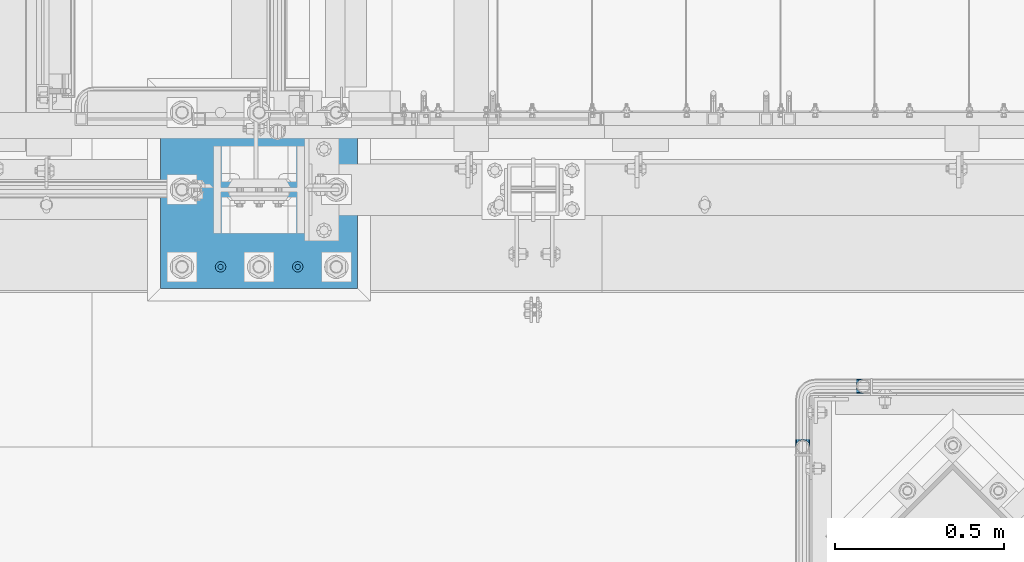
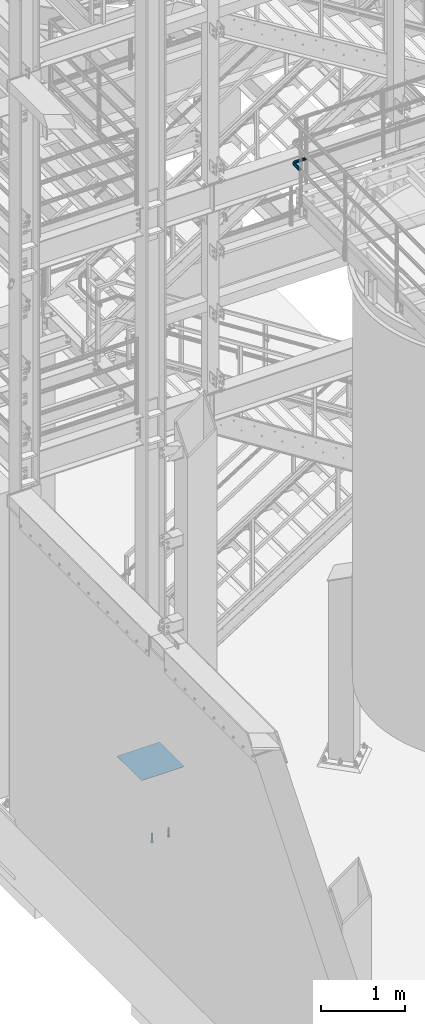
# One storey, part 1129 of 1876: 4 beams, 2 elements without a shape of their own.
"""IFC2X3 building model written with IfcOpenShell, lengths in millimetres."""

from ifc_helpers import new_model, si_unit, frame, origin_with_axes, place, context, subcontext, project, spatial, faceted_brep, material, type_object, element, aggregate, save


model = new_model("IFC2X3")

# Units and contexts
model_context = context("Model", 3, precision=1e-05, world=origin_with_axes())
body_context = subcontext(model_context, "Body", "Model", "MODEL_VIEW")
ifc_project = project(units=[si_unit("LENGTHUNIT", "METRE", prefix="MILLI"), si_unit("AREAUNIT", "SQUARE_METRE"), si_unit("VOLUMEUNIT", "CUBIC_METRE"), si_unit("MASSUNIT", "GRAM", prefix="KILO"), si_unit("TIMEUNIT", "SECOND"), si_unit("PLANEANGLEUNIT", "RADIAN"), si_unit("SOLIDANGLEUNIT", "STERADIAN"), si_unit("THERMODYNAMICTEMPERATUREUNIT", "DEGREE_CELSIUS"), si_unit("LUMINOUSINTENSITYUNIT", "LUMEN")], contexts=[model_context])

# Site, building, storey
site_placement = place(None, origin_with_axes())
site = spatial("IfcSite", under=ifc_project, at=site_placement, CompositionType="ELEMENT")
building_placement = place(site_placement, origin_with_axes())
building = spatial("IfcBuilding", under=site, at=building_placement, Name="Undefined", CompositionType="ELEMENT")
storey_placement = place(building_placement, origin_with_axes())
storey = spatial("IfcBuildingStorey", under=building, at=storey_placement, Name="Undefined", CompositionType="ELEMENT", Elevation=0.0)

# Assembly, beam
assembly_1_placement = place(storey_placement, origin_with_axes())
assembly_1 = element("IfcElementAssembly", 1, at=assembly_1_placement, inside=storey, Name="HANDRAIL", AssemblyPlace="NOTDEFINED", PredefinedType="RIGID_FRAME")
ifc_material_1 = material()
beam_type_1 = type_object("IfcBeamType", Name="PIPE1-1/4STD", PredefinedType="NOTDEFINED")
beam_1_placement = place(assembly_1_placement, frame((3517.90474593762, -7694.13240429563, 8480.425), z_axis=(0.0, 0.0, -1.0), x_axis=(-1.0, 0.0, 0.0)))
beam_1 = element("IfcBeam", 2, at=beam_1_placement, type_object=beam_type_1, material=ifc_material_1, Name="HANDRAIL", ObjectType="PIPE1-1/4STD", context=body_context, shape_type="Brep", body=[
    faceted_brep([(9.09494701772928e-13, 21.0820000000003, 0.0), (10.5409999957128, 18.2575475579433, -10.5409999999993), (10.5409999999983, 18.2575475625836, 10.5410000000011), (10.5409999999983, -18.2575475625836, 10.5410000000011), (10.5409999957128, -18.2575475672238, -10.5409999999993), (9.09494701772928e-13, -21.0820000000003, 0.0), (18.2575475625817, -10.5410000000011, 18.2575475625836), (18.2575475625817, -10.5409999999974, 13.3999612267289), (13.6205863358537, -15.1779612267255, 8.76300000000083), (11.2725475625793, -17.5259999999998, 0.0), (13.6205863358537, -15.1779612267255, -8.76299999999901), (18.2575475625817, -10.5409999999974, -13.3999612267271), (18.2575475625817, -10.5410000000011, -18.2575475625836), (21.0819999999985, 0.0, -17.5259999999998), (21.0819999999985, 0.0, -21.0819999999985), (18.7339612267233, -8.76300000000083, -15.1779612267255), (18.7339612267251, 8.76299999999901, -15.1779612267255), (18.2575475625817, 10.5410000000011, -13.3999612267235), (18.2575475625817, 10.5409999999993, -18.2575475625836), (13.6205863358573, 15.1779612267255, -8.76299999999901), (11.2725475625839, 17.5259999999998, 0.0), (13.6205863358573, 15.1779612267255, 8.76300000000083), (18.2575475625817, 10.5410000000011, 13.3999612267253), (18.2575475625817, 10.5409999999993, 18.2575475625836), (18.7339612267251, 8.76299999999901, 15.1779612267273), (21.0819999999985, 1.81898940354586e-12, 17.5259999999998), (21.0819999999985, 1.81898940354586e-12, 21.0820000000003), (18.7339612267233, -8.76300000000083, 15.1779612267273), (141.7320022583, -8.7629999999981, 15.1779612267255), (141.7320022583, 1.81898940354586e-12, 17.525999999998), (153.505549272468, -1.86474665447258, 17.525999999998), (150.797633350759, -10.1988549067664, 15.1779612267237), (141.7320022583, -15.1779612267246, 8.76299999999901), (148.815301313444, -16.2998455832249, 8.76299999999901), (141.732002258301, -17.5259999999989, -1.81898940354586e-12), (148.08971742905, -18.5329631590612, -1.81898940354586e-12), (141.7320022583, -15.1779612267246, -8.76300000000083), (148.815301313443, -16.2998455832249, -8.76300000000083), (141.7320022583, -8.76299999999901, -15.1779612267273), (150.797633350759, -10.1988549067664, -15.1779612267273), (141.7320022583, 1.81898940354586e-12, -17.5260000000017), (153.505549272467, -1.86474665447258, -17.5260000000017), (141.7320022583, 8.76300000000174, -15.1779612267273), (156.213465194176, 6.46936159782217, -15.1779612267273), (141.7320022583, 15.1779612267273, -8.76300000000083), (158.195797231491, 12.5703522742806, -8.76300000000083), (141.7320022583, 17.5260000000017, -1.81898940354586e-12), (158.921381115884, 14.803469850116, -1.81898940354586e-12), (141.7320022583, 15.1779612267273, 8.76299999999901), (158.195797231491, 12.5703522742806, 8.76299999999901), (141.7320022583, 8.76300000000174, 15.1779612267255), (156.213465194176, 6.46936159782217, 15.1779612267237), (179.832000732422, -38.0999984741202, -17.5260000000017), (171.069000732422, -38.0999984741202, -15.1779612267273), (171.069000732422, -161.097989750122, -15.1779612267255), (179.832000732422, -158.7499511731, -17.5259999999998), (188.595000732423, -38.0999984741202, -15.1779612267273), (188.595000732422, -161.097990142627, -15.1779612267255), (169.291000732422, -38.0999984741202, -18.2575475625854), (179.832000732422, -38.0999984741202, -21.0820000000003), (179.832000732422, -158.7499511731, -21.0820000000003), (169.291000732422, -161.574403610517, -18.2575475625836), (161.574453169838, -38.0999984741193, -10.5410000000011), (161.574453169838, -169.2909511731, -10.5409999999993), (158.750000732422, -38.0999984741193, -1.81898940354586e-12), (158.750000732422, -179.831954956055, 0.0), (161.574453169838, -169.2909511731, 10.5409999999993), (161.574453169839, -38.0999984741193, 10.5409999999993), (169.291000732423, -38.0999984741193, 18.2575475625817), (169.291000732422, -161.574403610517, 18.2575475625836), (179.832000732423, -38.0999984741193, 21.0819999999985), (179.832000732422, -158.7499511731, 21.0820000000003), (141.7320022583, 10.5410000000011, 18.2575475625817), (141.7320022583, 18.2575475625854, 10.5409999999993), (141.7320022583, 21.0820000000012, -1.81898940354586e-12), (141.7320022583, 18.2575475625854, -10.5410000000011), (141.7320022583, 10.5410000000011, -18.2575475625854), (141.7320022583, 1.81898940354586e-12, -21.0820000000022), (141.7320022583, -10.5409999999983, -18.2575475625854), (141.7320022583, -18.2575475625817, -10.5410000000011), (141.732002258301, -21.0819999999985, -1.81898940354586e-12), (141.7320022583, -18.2575475625817, 10.5409999999993), (141.7320022583, -10.5409999999983, 18.2575475625817), (141.7320022583, 1.81898940354586e-12, 21.0819999999985), (153.505549272468, -1.86474665447258, 21.0819999999985), (156.762897410175, 8.16034008379484, 18.2575475625817), (159.147441744916, 15.4992129264911, 10.5409999999993), (160.020245547882, 18.1854268220623, -1.81898940354586e-12), (159.147441744916, 15.4992129264911, -10.5410000000011), (156.762897410174, 8.16034008379484, -18.2575475625854), (153.505549272467, -1.86474665447258, -21.0820000000022), (150.24820113476, -11.8898333927391, -18.2575475625854), (147.863656800018, -19.2287062354353, -10.5410000000011), (146.990852997053, -21.9149201310065, -1.81898940354586e-12), (147.863656800019, -19.2287062354362, 10.5409999999993), (150.248201134761, -11.8898333927391, 18.2575475625817), (157.930775129339, -15.8043003606008, 18.2575475625817), (164.126619473753, -7.27645222289357, 21.0819999999985), (153.395102273439, -22.0471184766338, 10.5409999999993), (151.734930784924, -24.332148498308, -1.81898940354586e-12), (153.395102273439, -22.0471184766338, -10.5410000000011), (157.930775129338, -15.8043003606008, -18.2575475625854), (164.126619473752, -7.27645222289357, -21.0820000000022), (170.322463818167, 1.25139591481275, -18.2575475625854), (174.858136674066, 7.49421403084671, -10.5410000000011), (176.518308162581, 9.77924405251997, -1.81898940354586e-12), (174.858136674067, 7.49421403084671, 10.5409999999993), (170.322463818167, 1.25139591481275, 18.2575475625817), (172.555548509522, -15.7053812586619, 21.0819999999985), (181.083396647228, -9.50953691424547, 18.2575475625817), (164.027700371817, -21.9012256030774, 18.2575475625817), (157.784882255784, -26.4368984589782, 10.5409999999993), (155.499852234111, -28.0970699474938, -1.81898940354586e-12), (157.784882255784, -26.4368984589782, -10.5410000000011), (164.027700371817, -21.9012256030774, -18.2575475625854), (172.555548509522, -15.7053812586619, -21.0820000000022), (181.083396647228, -9.50953691424547, -18.2575475625854), (187.32621476326, -4.97386405834459, -10.5410000000011), (189.611244784934, -3.31369256982998, -1.81898940354586e-12), (187.32621476326, -4.97386405834459, 10.5409999999993), (187.992340816218, -23.0691033222502, 18.2575475625817), (195.331213658914, -20.6845589875093, 10.5409999999993), (177.96725407795, -26.3264514599559, 21.0819999999985), (167.942167339683, -29.5837995976626, 18.2575475625817), (160.603294496986, -31.9683439324035, 10.5409999999993), (157.917080601415, -32.8411477353693, -1.81898940354586e-12), (160.603294496986, -31.9683439324035, -10.5410000000011), (167.942167339682, -29.5837995976635, -18.2575475625854), (177.96725407795, -26.3264514599568, -21.0820000000022), (187.992340816217, -23.0691033222511, -18.2575475625854), (195.331213658914, -20.6845589875093, -10.5410000000011), (198.017427554485, -19.8117551845444, -1.81898940354586e-12), (198.089548295007, -38.0999984741193, 10.5409999999993), (200.914000732423, -38.0999984741202, -1.81898940354586e-12), (190.373000732423, -38.0999984741193, 18.2575475625817), (190.373000732422, -38.0999984741202, -18.2575475625854), (198.089548295006, -38.0999984741202, -10.5410000000011), (200.913999999997, -179.831951173101, 0.0), (198.089548295005, -169.2909511731, -10.5409999999993), (190.373000732422, -161.574403610517, -18.2575475625836), (190.372999999998, -161.574403610517, -13.3999619591505), (169.290999999997, -161.574403610517, -13.3999604943019), (164.654039505696, -38.0999984741193, -8.76300000000083), (164.654039505696, -166.211364104819, -8.76300000000083), (162.306000732422, -38.0999984741193, -1.81898940354586e-12), (162.306000732422, -168.559402878092, 0.0), (164.654039505696, -166.211364104819, 8.76299999999901), (169.290999999997, -161.574403610517, 13.3999604943019), (164.654039505696, -38.0999984741193, 8.76299999999901), (171.069000732422, -38.0999984741193, 15.1779612267255), (171.069000732422, -161.097989750122, 15.1779612267255), (179.832000732422, -158.7499511731, 17.5259999999998), (179.832000732423, -38.0999984741193, 17.525999999998), (188.595000732423, -38.0999984741193, 15.1779612267255), (188.595000732422, -161.097990142627, 15.1779612267255), (197.358000732423, -38.0999984741202, -1.81898940354586e-12), (195.009961959149, -38.0999984741202, -8.76300000000083), (195.009961959148, -166.211365569668, -8.76300000000083), (197.358000732422, -168.559404342942, 0.0), (195.009961959149, -38.0999984741193, 8.76299999999901), (195.009961959148, -166.211365569668, 8.76299999999901), (190.372999999998, -161.574403610517, 13.3999619591505), (190.373000732422, -161.574403610517, 18.2575475625836), (198.089548295005, -169.2909511731, 10.5409999999993), (186.301362330245, -23.6185355382495, -15.1779612267273), (192.402353006703, -21.6362035009342, -8.76300000000083), (177.96725407795, -26.3264514599568, -17.5260000000017), (169.633145825655, -29.0343673816642, -15.1779612267273), (163.532155149196, -31.0166994189794, -8.76300000000083), (161.299037573361, -31.7422833033716, -1.81898940354586e-12), (163.532155149197, -31.0166994189785, 8.76299999999901), (169.633145825655, -29.0343673816642, 15.1779612267255), (177.96725407795, -26.3264514599568, 17.525999999998), (186.301362330245, -23.6185355382486, 15.1779612267255), (192.402353006703, -21.6362035009342, 8.76299999999901), (194.635470582539, -20.9106196165412, -1.81898940354586e-12), (184.834777081907, -6.78399948972401, -8.76300000000083), (186.734380352937, -5.40385692698237, -1.81898940354586e-12), (179.644964431229, -10.5546190928217, -15.1779612267273), (172.555548509522, -15.7053812586619, -17.5260000000017), (165.466132587815, -20.8561434245012, -15.1779612267273), (160.276319937137, -24.6267630275997, -8.76300000000083), (158.376716666108, -26.0069055903414, -1.81898940354586e-12), (160.276319937138, -24.6267630275997, 8.76299999999901), (165.466132587815, -20.8561434245012, 15.1779612267237), (172.555548509522, -15.7053812586619, 17.525999999998), (179.64496443123, -10.5546190928217, 15.1779612267237), (184.834777081907, -6.7839994897231, 8.76299999999901), (174.428143805429, 6.90237962052288, -1.81898940354586e-12), (173.048001242688, 5.00277634949271, 8.76299999999901), (173.048001242688, 5.00277634949271, -8.76300000000083), (169.277381639591, -0.187036301185799, -15.1779612267273), (164.126619473753, -7.27645222289357, -17.5260000000017), (158.975857307914, -14.3658681446022, -15.1779612267273), (155.205237704817, -19.5556807952798, -8.76300000000083), (153.825095142076, -21.45528406631, -1.81898940354586e-12), (155.205237704817, -19.5556807952798, 8.76299999999901), (158.975857307914, -14.3658681446022, 15.1779612267237), (164.126619473753, -7.27645222289357, 17.525999999998), (169.277381639591, -0.187036301185799, 15.1779612267237)], [[[0, 1, 2]], [[3, 4, 5]], [[6, 7, 8, 9, 10, 11, 12, 4, 3]], [[13, 14, 12, 11, 15]], [[16, 17, 18, 14, 13]], [[2, 1, 18, 17, 19, 20, 21, 22, 23]], [[23, 22, 24, 25, 26]], [[26, 25, 27, 7, 6]], [[28, 29, 30, 31]], [[32, 28, 31, 33]], [[34, 32, 33, 35]], [[36, 34, 35, 37]], [[38, 36, 37, 39]], [[40, 38, 39, 41]], [[42, 40, 41, 43]], [[44, 42, 43, 45]], [[46, 44, 45, 47]], [[48, 46, 47, 49]], [[50, 48, 49, 51]], [[52, 53, 54, 55]], [[56, 52, 55, 57]], [[58, 59, 60, 61]], [[62, 58, 61, 63]], [[64, 62, 63, 65]], [[65, 63, 66]], [[67, 64, 65, 66]], [[68, 67, 66, 69]], [[70, 68, 69, 71]], [[72, 73, 2, 23]], [[73, 74, 0, 2]], [[74, 75, 1, 0]], [[75, 76, 18, 1]], [[76, 77, 14, 18]], [[77, 78, 12, 14]], [[78, 79, 4, 12]], [[79, 80, 5, 4]], [[80, 81, 3, 5]], [[81, 82, 6, 3]], [[82, 83, 26, 6]], [[83, 72, 23, 26]], [[72, 83, 84, 85]], [[73, 72, 85, 86]], [[74, 73, 86, 87]], [[75, 74, 87, 88]], [[76, 75, 88, 89]], [[77, 76, 89, 90]], [[78, 77, 90, 91]], [[79, 78, 91, 92]], [[80, 79, 92, 93]], [[81, 80, 93, 94]], [[82, 81, 94, 95]], [[83, 82, 95, 84]], [[95, 96, 97, 84]], [[94, 98, 96, 95]], [[93, 99, 98, 94]], [[92, 100, 99, 93]], [[91, 101, 100, 92]], [[90, 102, 101, 91]], [[89, 103, 102, 90]], [[88, 104, 103, 89]], [[87, 105, 104, 88]], [[86, 106, 105, 87]], [[85, 107, 106, 86]], [[84, 97, 107, 85]], [[97, 108, 109, 107]], [[96, 110, 108, 97]], [[98, 111, 110, 96]], [[99, 112, 111, 98]], [[100, 113, 112, 99]], [[101, 114, 113, 100]], [[102, 115, 114, 101]], [[103, 116, 115, 102]], [[104, 117, 116, 103]], [[105, 118, 117, 104]], [[106, 119, 118, 105]], [[107, 109, 119, 106]], [[109, 120, 121, 119]], [[108, 122, 120, 109]], [[110, 123, 122, 108]], [[111, 124, 123, 110]], [[112, 125, 124, 111]], [[113, 126, 125, 112]], [[114, 127, 126, 113]], [[115, 128, 127, 114]], [[116, 129, 128, 115]], [[117, 130, 129, 116]], [[118, 131, 130, 117]], [[119, 121, 131, 118]], [[121, 132, 133, 131]], [[120, 134, 132, 121]], [[122, 70, 134, 120]], [[123, 68, 70, 122]], [[124, 67, 68, 123]], [[125, 64, 67, 124]], [[126, 62, 64, 125]], [[127, 58, 62, 126]], [[128, 59, 58, 127]], [[129, 135, 59, 128]], [[130, 136, 135, 129]], [[131, 133, 136, 130]], [[136, 133, 137, 138]], [[135, 136, 138, 139]], [[59, 135, 139, 60]], [[57, 55, 60, 139, 140]], [[54, 141, 61, 60, 55]], [[53, 142, 143, 141, 54]], [[142, 144, 145, 143]], [[66, 63, 61, 141, 143, 145, 146, 147, 69]], [[144, 148, 146, 145]], [[146, 148, 149, 150, 147]], [[69, 147, 150, 151, 71]], [[149, 152, 151, 150]], [[152, 153, 154, 151]], [[155, 156, 157, 158]], [[159, 155, 158, 160]], [[154, 153, 159, 160, 161]], [[71, 151, 154, 161, 162]], [[134, 70, 71, 162]], [[132, 134, 162, 163]], [[133, 132, 163, 137]], [[137, 163, 138]], [[162, 161, 160, 158, 157, 140, 139, 138, 163]], [[156, 56, 57, 140, 157]], [[164, 56, 156, 165]], [[166, 52, 56, 164]], [[167, 53, 52, 166]], [[168, 142, 53, 167]], [[169, 144, 142, 168]], [[170, 148, 144, 169]], [[171, 149, 148, 170]], [[172, 152, 149, 171]], [[173, 153, 152, 172]], [[174, 159, 153, 173]], [[175, 155, 159, 174]], [[165, 156, 155, 175]], [[176, 165, 175, 177]], [[178, 164, 165, 176]], [[179, 166, 164, 178]], [[180, 167, 166, 179]], [[181, 168, 167, 180]], [[182, 169, 168, 181]], [[183, 170, 169, 182]], [[184, 171, 170, 183]], [[185, 172, 171, 184]], [[186, 173, 172, 185]], [[187, 174, 173, 186]], [[177, 175, 174, 187]], [[188, 177, 187, 189]], [[190, 176, 177, 188]], [[191, 178, 176, 190]], [[192, 179, 178, 191]], [[193, 180, 179, 192]], [[194, 181, 180, 193]], [[195, 182, 181, 194]], [[196, 183, 182, 195]], [[197, 184, 183, 196]], [[198, 185, 184, 197]], [[199, 186, 185, 198]], [[189, 187, 186, 199]], [[49, 189, 199, 51]], [[47, 188, 189, 49]], [[45, 190, 188, 47]], [[43, 191, 190, 45]], [[41, 192, 191, 43]], [[39, 193, 192, 41]], [[37, 194, 193, 39]], [[35, 195, 194, 37]], [[33, 196, 195, 35]], [[31, 197, 196, 33]], [[30, 198, 197, 31]], [[51, 199, 198, 30]], [[29, 50, 51, 30]], [[50, 29, 25, 24]], [[21, 48, 50, 24, 22]], [[46, 48, 21, 20]], [[44, 46, 20, 19]], [[42, 44, 19, 17, 16]], [[40, 42, 16, 13]], [[38, 40, 13, 15]], [[10, 36, 38, 15, 11]], [[34, 36, 10, 9]], [[32, 34, 9, 8]], [[28, 32, 8, 7, 27]], [[29, 28, 27, 25]]]),
])
aggregate(assembly_1, [beam_1])

# Assembly, beams
assembly_2_placement = place(storey_placement, origin_with_axes())
assembly_2 = element("IfcElementAssembly", 3, at=assembly_2_placement, inside=storey, Name="TEMPLATE", AssemblyPlace="NOTDEFINED", PredefinedType="RIGID_FRAME")
ifc_material_2 = material(Name="STEEL/A108")
beam_type_2 = type_object("IfcBeamType", Name="5/8-DIA_HEADED ANCHOR STUD", PredefinedType="NOTDEFINED")
beam_2_placement = place(assembly_2_placement, frame((1841.5, -7340.6, -819.15), z_axis=(1.0, 0.0, 0.0), x_axis=(0.0, 0.0, -1.0)))
beam_2 = element("IfcBeam", 4, at=beam_2_placement, type_object=beam_type_2, material=ifc_material_2, Name="HEADED ANCHOR STUD", ObjectType="5/8-DIA_HEADED ANCHOR STUD", context=body_context, shape_type="Brep", body=[
    faceted_brep([(0.0, -7.94000005722046, 0.0), (0.0, -6.86999988555908, -3.97000002861023), (116.84, -6.86999988555908, -3.97000002861023), (116.84, -7.94000005722046, 0.0), (0.0, -3.97000002861023, -6.86999988555908), (116.84, -3.97000002861023, -6.86999988555908), (0.0, 0.0, -7.94000005722046), (116.84, 0.0, -7.94000005722046), (0.0, 3.97000002861023, -6.86999988555908), (116.84, 3.97000002861023, -6.86999988555908), (0.0, 6.86999988555908, -3.97000002861023), (116.84, 6.86999988555908, -3.97000002861023), (0.0, 7.94000005722046, 0.0), (116.84, 7.94000005722046, 0.0), (0.0, 6.86999988555908, 3.97000002861023), (116.84, 6.86999988555908, 3.97000002861023), (0.0, 3.97000002861023, 6.86999988555908), (116.84, 3.97000002861023, 6.86999988555908), (0.0, 0.0, 7.94000005722046), (116.84, 0.0, 7.94000005722046), (0.0, -3.97000002861023, 6.86999988555908), (116.84, -3.97000002861023, 6.86999988555908), (0.0, -6.86999988555908, 3.97000002861023), (116.84, -6.86999988555908, 3.97000002861023), (118.11, -13.75, -7.94000005722046), (118.11, -15.8800001144409, 0.0), (118.11, -7.94000005722046, -13.75), (118.11, 0.0, -15.8800001144409), (118.11, 7.94000005722046, -13.75), (118.11, 13.75, -7.94000005722046), (118.11, 15.8800001144409, 0.0), (118.11, 13.75, 7.94000005722046), (118.11, 7.94000005722046, 13.75), (118.11, 0.0, 15.8800001144409), (118.11, -7.94000005722046, 13.75), (118.11, -13.75, 7.94000005722046), (127.0, -13.75, -7.94000005722046), (127.0, -15.8800001144409, 0.0), (127.0, -7.94000005722046, -13.75), (127.0, 0.0, -15.8800001144409), (127.0, 7.94000005722046, -13.75), (127.0, 13.75, -7.94000005722046), (127.0, 15.8800001144409, 0.0), (127.0, 13.75, 7.94000005722046), (127.0, 7.94000005722046, 13.75), (127.0, 0.0, 15.8800001144409), (127.0, -7.94000005722046, 13.75), (127.0, -13.75, 7.94000005722046)], [[[0, 1, 2, 3]], [[1, 4, 5, 2]], [[4, 6, 7, 5]], [[6, 8, 9, 7]], [[8, 10, 11, 9]], [[10, 12, 13, 11]], [[12, 14, 15, 13]], [[14, 16, 17, 15]], [[16, 18, 19, 17]], [[18, 20, 21, 19]], [[20, 22, 23, 21]], [[22, 0, 3, 23]], [[22, 20, 18, 16, 14, 12, 10, 8, 6, 4, 1, 0]], [[3, 2, 24, 25]], [[2, 5, 26, 24]], [[5, 7, 27, 26]], [[7, 9, 28, 27]], [[9, 11, 29, 28]], [[11, 13, 30, 29]], [[13, 15, 31, 30]], [[15, 17, 32, 31]], [[17, 19, 33, 32]], [[19, 21, 34, 33]], [[21, 23, 35, 34]], [[23, 3, 25, 35]], [[25, 24, 36, 37]], [[24, 26, 38, 36]], [[26, 27, 39, 38]], [[27, 28, 40, 39]], [[28, 29, 41, 40]], [[29, 30, 42, 41]], [[30, 31, 43, 42]], [[31, 32, 44, 43]], [[32, 33, 45, 44]], [[33, 34, 46, 45]], [[34, 35, 47, 46]], [[35, 25, 37, 47]], [[38, 39, 40, 41, 42, 43, 44, 45, 46, 47, 37, 36]]]),
])
beam_3_placement = place(assembly_2_placement, frame((1612.9, -7340.6, -819.15), z_axis=(1.0, 0.0, 0.0), x_axis=(0.0, 0.0, -1.0)))
beam_3 = element("IfcBeam", 5, at=beam_3_placement, type_object=beam_type_2, material=ifc_material_2, Name="HEADED ANCHOR STUD", ObjectType="5/8-DIA_HEADED ANCHOR STUD", context=body_context, shape_type="Brep", body=[
    faceted_brep([(0.0, -7.94000005722046, 0.0), (0.0, -6.86999988555908, -3.97000002861023), (116.84, -6.86999988555908, -3.97000002861023), (116.84, -7.94000005722046, 0.0), (0.0, -3.97000002861023, -6.86999988555908), (116.84, -3.97000002861023, -6.86999988555908), (0.0, 0.0, -7.94000005722046), (116.84, 0.0, -7.94000005722046), (0.0, 3.97000002861023, -6.86999988555908), (116.84, 3.97000002861023, -6.86999988555908), (0.0, 6.86999988555908, -3.97000002861023), (116.84, 6.86999988555908, -3.97000002861023), (0.0, 7.94000005722046, 0.0), (116.84, 7.94000005722046, 0.0), (0.0, 6.86999988555908, 3.97000002861023), (116.84, 6.86999988555908, 3.97000002861023), (0.0, 3.97000002861023, 6.86999988555908), (116.84, 3.97000002861023, 6.86999988555908), (0.0, 0.0, 7.94000005722046), (116.84, 0.0, 7.94000005722046), (0.0, -3.97000002861023, 6.86999988555908), (116.84, -3.97000002861023, 6.86999988555908), (0.0, -6.86999988555908, 3.97000002861023), (116.84, -6.86999988555908, 3.97000002861023), (118.11, -13.75, -7.94000005722046), (118.11, -15.8800001144409, 0.0), (118.11, -7.94000005722046, -13.75), (118.11, 0.0, -15.8800001144409), (118.11, 7.94000005722046, -13.75), (118.11, 13.75, -7.94000005722046), (118.11, 15.8800001144409, 0.0), (118.11, 13.75, 7.94000005722046), (118.11, 7.94000005722046, 13.75), (118.11, 0.0, 15.8800001144409), (118.11, -7.94000005722046, 13.75), (118.11, -13.75, 7.94000005722046), (127.0, -13.75, -7.94000005722046), (127.0, -15.8800001144409, 0.0), (127.0, -7.94000005722046, -13.75), (127.0, 0.0, -15.8800001144409), (127.0, 7.94000005722046, -13.75), (127.0, 13.75, -7.94000005722046), (127.0, 15.8800001144409, 0.0), (127.0, 13.75, 7.94000005722046), (127.0, 7.94000005722046, 13.75), (127.0, 0.0, 15.8800001144409), (127.0, -7.94000005722046, 13.75), (127.0, -13.75, 7.94000005722046)], [[[0, 1, 2, 3]], [[1, 4, 5, 2]], [[4, 6, 7, 5]], [[6, 8, 9, 7]], [[8, 10, 11, 9]], [[10, 12, 13, 11]], [[12, 14, 15, 13]], [[14, 16, 17, 15]], [[16, 18, 19, 17]], [[18, 20, 21, 19]], [[20, 22, 23, 21]], [[22, 0, 3, 23]], [[22, 20, 18, 16, 14, 12, 10, 8, 6, 4, 1, 0]], [[3, 2, 24, 25]], [[2, 5, 26, 24]], [[5, 7, 27, 26]], [[7, 9, 28, 27]], [[9, 11, 29, 28]], [[11, 13, 30, 29]], [[13, 15, 31, 30]], [[15, 17, 32, 31]], [[17, 19, 33, 32]], [[19, 21, 34, 33]], [[21, 23, 35, 34]], [[23, 3, 25, 35]], [[25, 24, 36, 37]], [[24, 26, 38, 36]], [[26, 27, 39, 38]], [[27, 28, 40, 39]], [[28, 29, 41, 40]], [[29, 30, 42, 41]], [[30, 31, 43, 42]], [[31, 32, 44, 43]], [[32, 33, 45, 44]], [[33, 34, 46, 45]], [[34, 35, 47, 46]], [[35, 25, 37, 47]], [[38, 39, 40, 41, 42, 43, 44, 45, 46, 47, 37, 36]]]),
])
ifc_material_3 = material(Name="STEEL/A572-50")
beam_type_3 = type_object("IfcBeamType", PredefinedType="NOTDEFINED")
beam_4_placement = place(assembly_2_placement, frame((2019.3, -7112.0, 40.4815), z_axis=(0.0, -1.0, 0.0), x_axis=(-1.0, 0.0, 0.0)))
beam_4 = element("IfcBeam", 6, at=beam_4_placement, type_object=beam_type_3, material=ifc_material_3, Name="TEMPLATE", context=body_context, shape_type="Brep", body=[
    faceted_brep([(0.0, 2.3815, -292.1), (0.0, 2.3815, 292.1), (584.200000000001, 2.3815, 292.1), (584.200000000001, 2.3815, -292.1), (0.0, -2.3815, 292.1), (584.200000000001, -2.3815, 292.1), (0.0, -2.3815, -292.1), (584.200000000001, -2.3815, -292.1)], [[[0, 1, 2, 3]], [[1, 4, 5, 2]], [[4, 6, 7, 5]], [[6, 0, 3, 7]], [[5, 7, 3, 2]], [[6, 4, 1, 0]]]),
])
aggregate(assembly_2, [beam_2, beam_3, beam_4])

save(model, "model.ifc")
